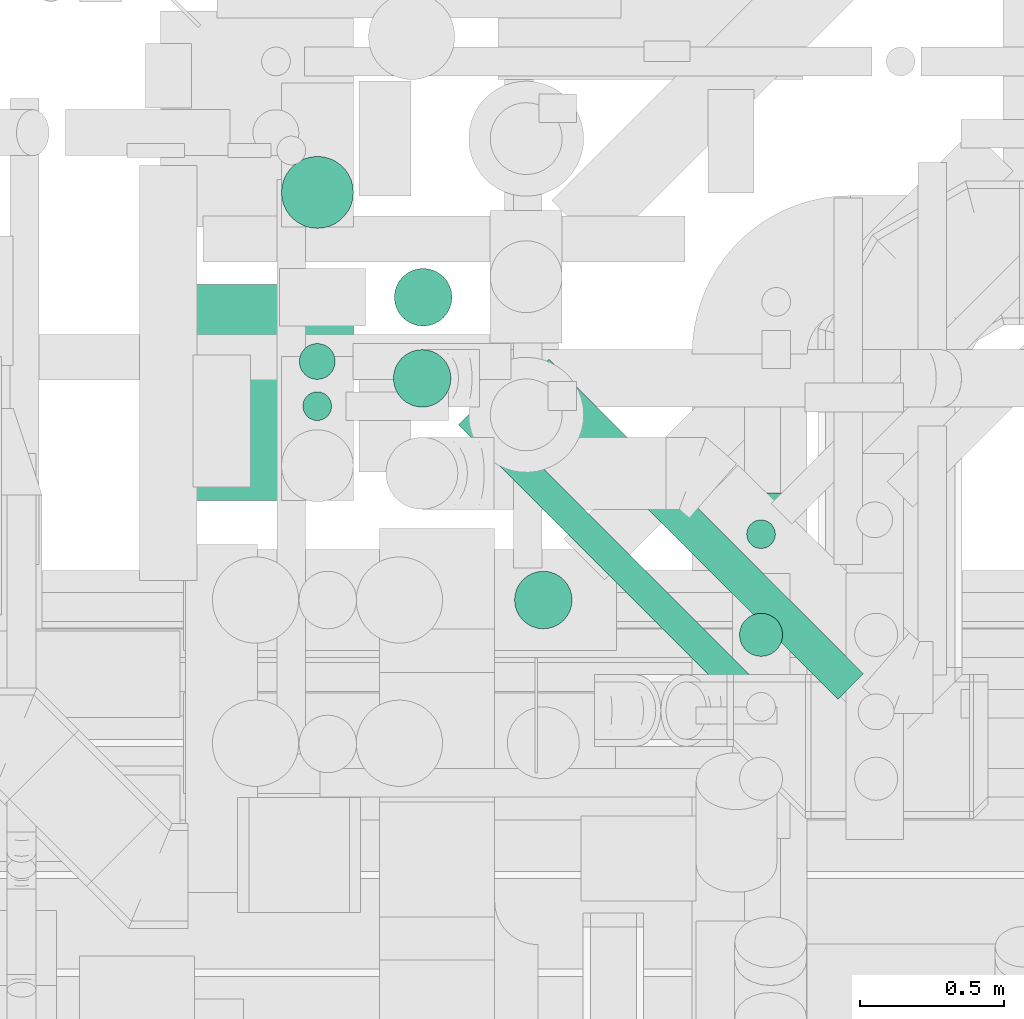
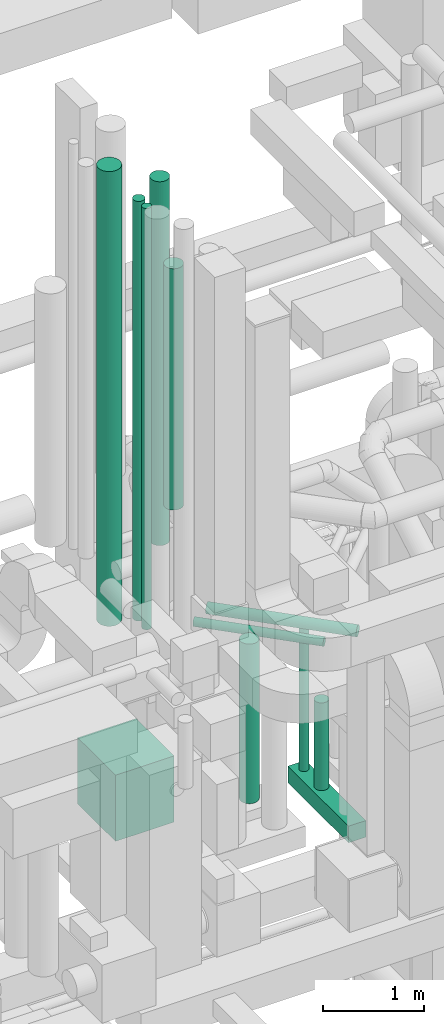
# One storey, part 53 of 337: 12 flow segments.
"""IFC2X3 building model written with IfcOpenShell, lengths in millimetres."""

from ifc_helpers import new_model, entity, si_unit, converted_unit, derived_unit, direction, frame, origin, origin_2d_with_axis, place, context, subcontext, project, spatial, rectangle, circle, extrude, type_object, element, save


model = new_model("IFC2X3")

# Units and contexts
model_context = context("Model", 3, precision=0.01, world=origin(), true_north=direction((6.12303176911189e-17, 1.0)))
body_context = subcontext(model_context, "Body", "Model", "MODEL_VIEW")
ifc_project = project(units=[si_unit("LENGTHUNIT", "METRE", prefix="MILLI"), si_unit("AREAUNIT", "SQUARE_METRE"), si_unit("VOLUMEUNIT", "CUBIC_METRE"), converted_unit("PLANEANGLEUNIT", "DEGREE", entity("IfcRatioMeasure", 0.0174532925199433), si_unit("PLANEANGLEUNIT", "RADIAN"), dimensions=[0, 0, 0, 0, 0, 0, 0]), si_unit("MASSUNIT", "GRAM", prefix="KILO"), derived_unit("MASSDENSITYUNIT", [(si_unit("MASSUNIT", "GRAM", prefix="KILO"), 1), (si_unit("LENGTHUNIT", "METRE"), -3)]), derived_unit("MOMENTOFINERTIAUNIT", [(si_unit("LENGTHUNIT", "METRE"), 4)]), si_unit("TIMEUNIT", "SECOND"), si_unit("FREQUENCYUNIT", "HERTZ"), si_unit("THERMODYNAMICTEMPERATUREUNIT", "DEGREE_CELSIUS"), derived_unit("THERMALTRANSMITTANCEUNIT", [(si_unit("MASSUNIT", "GRAM", prefix="KILO"), 1), (si_unit("THERMODYNAMICTEMPERATUREUNIT", "KELVIN"), -1), (si_unit("TIMEUNIT", "SECOND"), -3)]), derived_unit("VOLUMETRICFLOWRATEUNIT", [(si_unit("LENGTHUNIT", "METRE"), 3), (si_unit("TIMEUNIT", "SECOND"), -1)]), derived_unit("MASSFLOWRATEUNIT", [(si_unit("MASSUNIT", "GRAM", prefix="KILO"), 1), (si_unit("TIMEUNIT", "SECOND"), -1)]), derived_unit("ROTATIONALFREQUENCYUNIT", [(si_unit("TIMEUNIT", "SECOND"), -1)]), si_unit("ELECTRICCURRENTUNIT", "AMPERE"), si_unit("ELECTRICVOLTAGEUNIT", "VOLT"), si_unit("POWERUNIT", "WATT"), si_unit("FORCEUNIT", "NEWTON", prefix="KILO"), si_unit("ILLUMINANCEUNIT", "LUX"), si_unit("LUMINOUSFLUXUNIT", "LUMEN"), si_unit("LUMINOUSINTENSITYUNIT", "CANDELA"), derived_unit("USERDEFINED", [(si_unit("MASSUNIT", "GRAM", prefix="KILO"), -1), (si_unit("LENGTHUNIT", "METRE"), -2), (si_unit("TIMEUNIT", "SECOND"), 3), (si_unit("LUMINOUSFLUXUNIT", "LUMEN"), 1)]), derived_unit("LINEARVELOCITYUNIT", [(si_unit("LENGTHUNIT", "METRE"), 1), (si_unit("TIMEUNIT", "SECOND"), -1)]), si_unit("PRESSUREUNIT", "PASCAL"), derived_unit("USERDEFINED", [(si_unit("LENGTHUNIT", "METRE"), -2), (si_unit("MASSUNIT", "GRAM", prefix="KILO"), 1), (si_unit("TIMEUNIT", "SECOND"), -2)]), derived_unit("LINEARFORCEUNIT", [(si_unit("MASSUNIT", "GRAM", prefix="KILO"), 1), (si_unit("LENGTHUNIT", "METRE"), 1), (si_unit("TIMEUNIT", "SECOND"), -2), (si_unit("LENGTHUNIT", "METRE"), -1)]), derived_unit("PLANARFORCEUNIT", [(si_unit("MASSUNIT", "GRAM", prefix="KILO"), 1), (si_unit("LENGTHUNIT", "METRE"), 1), (si_unit("TIMEUNIT", "SECOND"), -2), (si_unit("LENGTHUNIT", "METRE"), -2)])], contexts=[model_context])

# Site, building, storey
site_placement = place(None, origin())
site = spatial("IfcSite", under=ifc_project, at=site_placement, CompositionType="ELEMENT")
building_placement = place(site_placement, origin())
building = spatial("IfcBuilding", under=site, at=building_placement, CompositionType="ELEMENT")
storey_placement = place(building_placement, origin())
storey = spatial("IfcBuildingStorey", under=building, at=storey_placement, CompositionType="ELEMENT", Elevation=0.0)

# Flow segments
duct_segment_type_1 = type_object("IfcDuctSegmentType", PredefinedType="NOTDEFINED")
flow_segment_1_placement = place(storey_placement, frame((57036.5, 9405.81, 28400.0)))
element("IfcFlowSegment", 1, at=flow_segment_1_placement, inside=storey, type_object=duct_segment_type_1, context=body_context, shape_type="SweptSolid", body=[
    extrude(rectangle(XDim=1200.0, YDim=199.999999999998, at=origin_2d_with_axis()), frame((100.0, 600.0, 0.0), z_axis=(0.0, 0.0, 1.0), x_axis=(0.0, 1.0, 0.0)), (0.0, 0.0, 1.0), 199.999999999998),
])
flow_segment_2_placement = place(storey_placement, frame((55050.02, 10580.6, 28400.0)))
element("IfcFlowSegment", 2, at=flow_segment_2_placement, inside=storey, type_object=duct_segment_type_1, context=body_context, shape_type="SweptSolid", body=[
    extrude(rectangle(XDim=749.999999999998, YDim=670.000000000004, at=origin_2d_with_axis()), frame((335.0, 375.0, 0.0), z_axis=(0.0, 0.0, 1.0), x_axis=(0.0, -1.0, 0.0)), (0.0, 0.0, 1.0), 800.0),
])
duct_segment_type_2 = type_object("IfcDuctSegmentType", PredefinedType="NOTDEFINED")
flow_segment_3_placement = place(storey_placement, frame((55860.9, 11184.64, 31300.0)))
element("IfcFlowSegment", 3, at=flow_segment_3_placement, inside=storey, type_object=duct_segment_type_2, context=body_context, shape_type="SweptSolid", body=[
    extrude(circle(Radius=100.0, at=origin_2d_with_axis()), frame((101.6, 101.6, 0.0), z_axis=(0.0, 0.0, 1.0), x_axis=(0.0, -1.0, 0.0)), (0.0, 0.0, 1.0), 4400.00000000001),
])
flow_segment_4_placement = place(storey_placement, frame((55530.32, 10998.9, 30625.0)))
element("IfcFlowSegment", 4, at=flow_segment_4_placement, inside=storey, type_object=duct_segment_type_2, context=body_context, shape_type="SweptSolid", body=[
    extrude(circle(Radius=62.5, at=origin_2d_with_axis()), frame((64.1, 64.1, 0.0), z_axis=(0.0, 0.0, 1.0), x_axis=(0.0, 1.0, 0.0)), (0.0, 0.0, 1.0), 5074.99999999962),
])
flow_segment_5_placement = place(storey_placement, frame((55542.82, 10856.12, 30605.0)))
element("IfcFlowSegment", 5, at=flow_segment_5_placement, inside=storey, type_object=duct_segment_type_2, context=body_context, shape_type="SweptSolid", body=[
    extrude(circle(Radius=50.0, at=origin_2d_with_axis()), frame((51.6, 51.6, 0.0), z_axis=(0.0, 0.0, 1.0), x_axis=(0.0, 1.0, 0.0)), (0.0, 0.0, 1.0), 5094.99999999964),
])
flow_segment_6_placement = place(storey_placement, frame((56083.94, 9896.57, 30453.4)))
element("IfcFlowSegment", 6, at=flow_segment_6_placement, inside=storey, type_object=duct_segment_type_2, context=body_context, shape_type="SweptSolid", body=[
    extrude(circle(Radius=50.0, at=origin_2d_with_axis()), frame((36.95, 981.85, 51.6), z_axis=(0.707106781186544, -0.707106781186551, 0.0), x_axis=(-0.707106781186551, -0.707106781186544, 0.0)), (0.0, 0.0, 1.0), 1336.28805094981),
])
flow_segment_7_placement = place(storey_placement, frame((57059.9, 10036.46, 28620.0)))
element("IfcFlowSegment", 7, at=flow_segment_7_placement, inside=storey, type_object=duct_segment_type_2, context=body_context, shape_type="SweptSolid", body=[
    extrude(circle(Radius=75.0, at=origin_2d_with_axis()), frame((76.6, 76.6, 0.0), z_axis=(0.0, 0.0, 1.0), x_axis=(-1.0, 0.0, 0.0)), (0.0, 0.0, 1.0), 1059.99999999997),
])
flow_segment_8_placement = place(storey_placement, frame((57084.9, 10411.22, 28620.0)))
element("IfcFlowSegment", 8, at=flow_segment_8_placement, inside=storey, type_object=duct_segment_type_2, context=body_context, shape_type="SweptSolid", body=[
    extrude(circle(Radius=50.0, at=origin_2d_with_axis()), frame((51.6, 51.6, 0.0), z_axis=(0.0, 0.0, 1.0), x_axis=(-1.0, 0.0, 0.0)), (0.0, 0.0, 1.0), 1779.99999999997),
])
flow_segment_9_placement = place(storey_placement, frame((56278.4, 10132.47, 28670.0)))
element("IfcFlowSegment", 9, at=flow_segment_9_placement, inside=storey, type_object=duct_segment_type_2, context=body_context, shape_type="SweptSolid", body=[
    extrude(circle(Radius=100.0, at=origin_2d_with_axis()), frame((101.6, 101.6, 0.0), z_axis=(0.0, 0.0, 1.0), x_axis=(0.0, 1.0, 0.0)), (0.0, 0.0, 1.0), 1929.99999999997),
])
flow_segment_10_placement = place(storey_placement, frame((55857.4, 10902.63, 31901.04)))
element("IfcFlowSegment", 10, at=flow_segment_10_placement, inside=storey, type_object=duct_segment_type_2, context=body_context, shape_type="SweptSolid", body=[
    extrude(circle(Radius=100.0, at=origin_2d_with_axis()), frame((101.6, 101.6, 0.0), z_axis=(0.0, 0.0, 1.0), x_axis=(0.0, -1.0, 0.0)), (0.0, 0.0, 1.0), 2918.95923652568),
])
flow_segment_11_placement = place(storey_placement, frame((55468.43, 11524.01, 30248.56)))
element("IfcFlowSegment", 11, at=flow_segment_11_placement, inside=storey, type_object=duct_segment_type_2, context=body_context, shape_type="SweptSolid", body=[
    extrude(circle(Radius=125.0, at=origin_2d_with_axis()), frame((126.6, 126.6, 0.0), z_axis=(0.0, 0.0, 1.0), x_axis=(-1.0, 0.0, 0.0)), (0.0, 0.0, 1.0), 5500.0),
])
flow_segment_12_placement = place(storey_placement, frame((56310.14, 9888.41, 30435.9)))
element("IfcFlowSegment", 12, at=flow_segment_12_placement, inside=storey, type_object=duct_segment_type_2, context=body_context, shape_type="SweptSolid", body=[
    extrude(circle(Radius=62.5, at=origin_2d_with_axis()), frame((45.79, 1137.98, 64.1), z_axis=(0.707106781186549, -0.707106781186546, 0.0), x_axis=(-0.707106781186546, -0.707106781186549, 0.0)), (0.0, 0.0, 1.0), 1544.58373010984),
])

save(model, "model.ifc")
